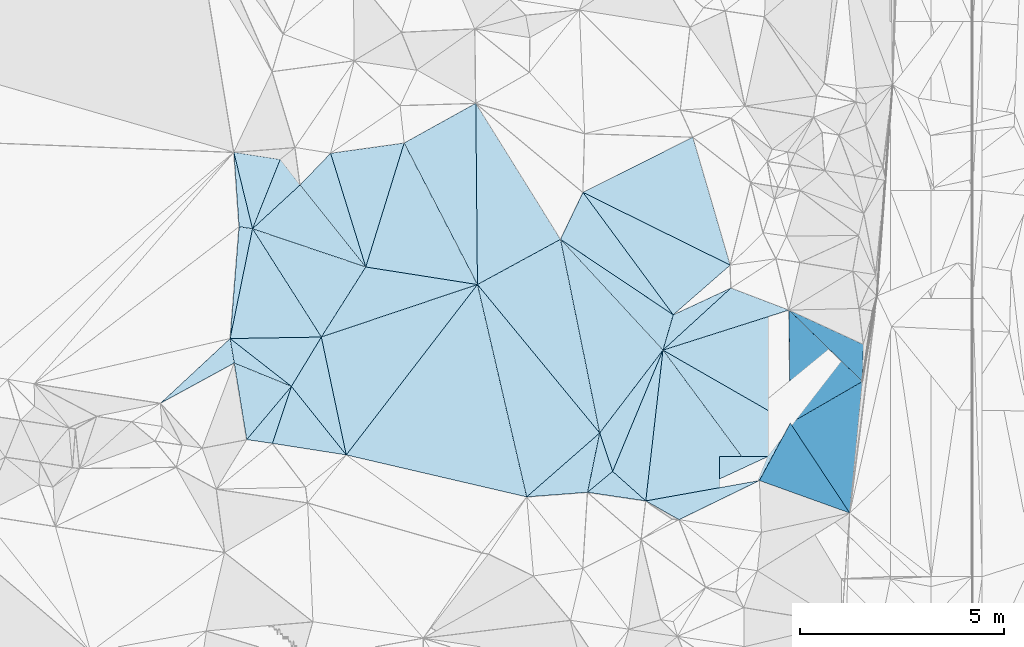
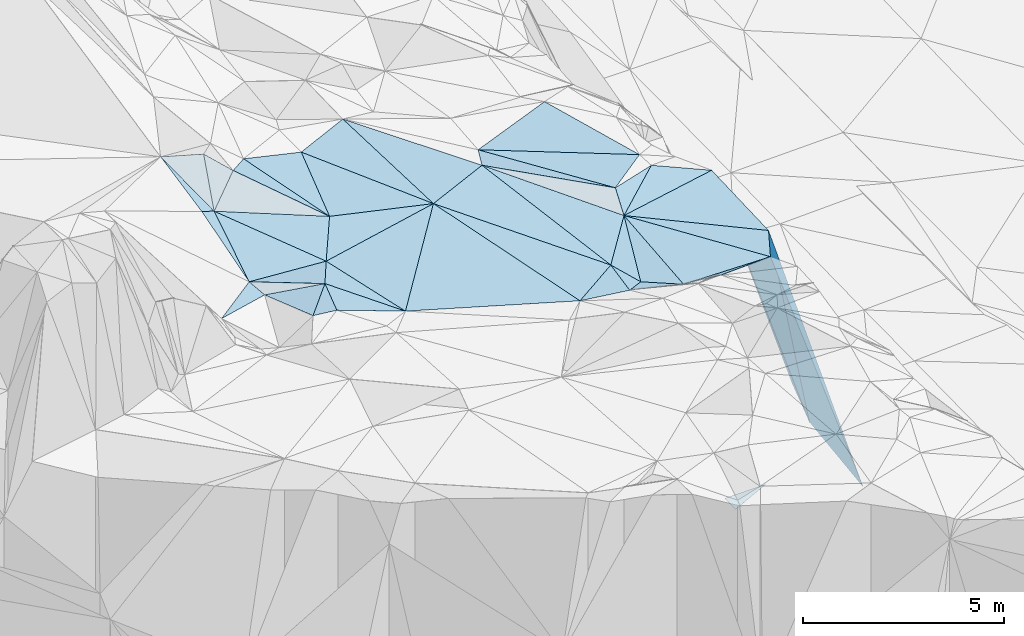
# One storey, part 127 of 275: 45 plates.
"""IFC2X3 building model written with IfcOpenShell, lengths in millimetres."""

from ifc_helpers import new_model, si_unit, frame, origin_with_axes, place, context, subcontext, project, spatial, polyline, outline, extrude, material, type_object, element, save


model = new_model("IFC2X3")

# Units and contexts
model_context = context("Model", 3, precision=1e-05, world=origin_with_axes())
body_context = subcontext(model_context, "Body", "Model", "MODEL_VIEW")
ifc_project = project(units=[si_unit("LENGTHUNIT", "METRE", prefix="MILLI"), si_unit("AREAUNIT", "SQUARE_METRE"), si_unit("VOLUMEUNIT", "CUBIC_METRE"), si_unit("MASSUNIT", "GRAM", prefix="KILO"), si_unit("TIMEUNIT", "SECOND"), si_unit("PLANEANGLEUNIT", "RADIAN"), si_unit("SOLIDANGLEUNIT", "STERADIAN"), si_unit("THERMODYNAMICTEMPERATUREUNIT", "DEGREE_CELSIUS"), si_unit("LUMINOUSINTENSITYUNIT", "LUMEN")], contexts=[model_context])

# Site, building, storey
site_placement = place(None, origin_with_axes())
site = spatial("IfcSite", under=ifc_project, at=site_placement, CompositionType="ELEMENT")
building_placement = place(site_placement, origin_with_axes())
building = spatial("IfcBuilding", under=site, at=building_placement, Name="Undefined", CompositionType="ELEMENT")
storey_placement = place(building_placement, origin_with_axes())
storey = spatial("IfcBuildingStorey", under=building, at=storey_placement, Name="Undefined", CompositionType="ELEMENT", Elevation=0.0)

# Plates
ifc_material = material()
plate_type_1 = type_object("IfcPlateType", PredefinedType="NOTDEFINED")
plate_1_placement = place(storey_placement, frame((-113290.924516379, 114127.260500849, 53479.508927416), z_axis=(-0.172709102162707, 0.0752053051916001, -0.982097616380974), x_axis=(0.930589104773864, -0.314271187618271, -0.187716644731307)))
element("IfcPlate", 1, at=plate_1_placement, inside=storey, type_object=plate_type_1, material=ifc_material, Name="00", context=body_context, shape_type="SweptSolid", body=[
    extrude(outline(polyline([(0.0, 0.0), (2983.2197265625, 1.45373633131385e-08), (2498.30737304688, 1975.21142578125), (0.0, 0.0)])), frame((-8.85201319254618e-08, 2.18876761149539e-07, -0.5000001331573), z_axis=(0.0, 0.0, 1.0), x_axis=(1.0, 0.0, 0.0)), (0.0, 0.0, 1.0), 1.0),
])
plate_type_2 = type_object("IfcPlateType", PredefinedType="NOTDEFINED")
plate_2_placement = place(storey_placement, frame((-100142.417613451, 112133.663950851, 51329.8786760674), z_axis=(-0.970123067649742, 0.00204934980498017, -0.242604686226857), x_axis=(0.235700499270644, -0.229042311999375, -0.944449519009645)))
element("IfcPlate", 2, at=plate_2_placement, inside=storey, type_object=plate_type_2, material=ifc_material, Name="00", context=body_context, shape_type="SweptSolid", body=[
    extrude(outline(polyline([(0.0, 0.0), (7644.6650390625, 1.2892996892333e-08), (794.29248046875, 2661.82250976563), (0.0, 0.0)])), frame((-8.85201319254618e-08, 2.18876761149539e-07, -0.5000001331573), z_axis=(0.0, 0.0, 1.0), x_axis=(1.0, 0.0, 0.0)), (0.0, 0.0, 1.0), 1.0),
])
plate_type_3 = type_object("IfcPlateType", PredefinedType="NOTDEFINED")
plate_3_placement = place(storey_placement, frame((-102977.166585272, 112017.290992687, 51859.5340615484), z_axis=(-0.307575091997798, -0.192578028302466, -0.931832209036413), x_axis=(-0.820654845992236, 0.549332950676006, 0.157349715764129)))
element("IfcPlate", 3, at=plate_3_placement, inside=storey, type_object=plate_type_3, material=ifc_material, Name="00", context=body_context, shape_type="SweptSolid", body=[
    extrude(outline(polyline([(0.0, 0.0), (3368.29345703125, -2.82307155430317e-08), (3482.03051757813, 1339.12805175781), (0.0, 0.0)])), frame((-8.85201319254618e-08, 2.18876761149539e-07, -0.5000001331573), z_axis=(0.0, 0.0, 1.0), x_axis=(1.0, 0.0, 0.0)), (0.0, 0.0, 1.0), 1.0),
])
plate_type_4 = type_object("IfcPlateType", PredefinedType="NOTDEFINED")
plate_4_placement = place(storey_placement, frame((-103228.629908581, 111151.950283481, 51629.548500811), z_axis=(-0.284072273763953, 0.322455013222665, -0.902953879069218), x_axis=(0.270325176584008, 0.930481862748815, 0.247240372917369)))
element("IfcPlate", 4, at=plate_4_placement, inside=storey, type_object=plate_type_4, material=ifc_material, Name="00", context=body_context, shape_type="SweptSolid", body=[
    extrude(outline(polyline([(0.0, 0.0), (930.268798828125, -2.6775524020195e-09), (1873.22204589844, 1260.72961425781), (0.0, 0.0)])), frame((-8.85201319254618e-08, 2.18876761149539e-07, -0.5000001331573), z_axis=(0.0, 0.0, 1.0), x_axis=(1.0, 0.0, 0.0)), (0.0, 0.0, 1.0), 1.0),
])
plate_type_5 = type_object("IfcPlateType", PredefinedType="NOTDEFINED")
plate_5_placement = place(storey_placement, frame((-101843.498270915, 107992.439060405, 44125.3050804354), z_axis=(0.0127811447682837, 0.0127271104742126, -0.999837318266021), x_axis=(0.00421432091108771, 0.999909427151692, 0.0127819009710444)))
element("IfcPlate", 5, at=plate_5_placement, inside=storey, type_object=plate_type_5, material=ifc_material, Name="00_PR", context=body_context, shape_type="SweptSolid", body=[
    extrude(outline(polyline([(0.0, 0.0), (550.387634277344, -1.93540472537279e-09), (555.515625, 1186.86450195313), (0.0, 0.0)])), frame((-8.85201319254618e-08, 2.18876761149539e-07, -0.5000001331573), z_axis=(0.0, 0.0, 1.0), x_axis=(1.0, 0.0, 0.0)), (0.0, 0.0, 1.0), 1.0),
])
plate_type_6 = type_object("IfcPlateType", PredefinedType="NOTDEFINED")
plate_6_placement = place(storey_placement, frame((-110992.967145361, 108582.937779977, 52999.5228277071), z_axis=(-0.29101831444903, -0.0680980094244274, -0.954290837097201), x_axis=(-0.619116988685024, 0.773853922782803, 0.133582410950151)))
element("IfcPlate", 6, at=plate_6_placement, inside=storey, type_object=plate_type_6, material=ifc_material, Name="00", context=body_context, shape_type="SweptSolid", body=[
    extrude(outline(polyline([(0.0, 0.0), (2170.94458007813, -1.24782673083246e-08), (2611.72045898438, 1379.67993164063), (0.0, 0.0)])), frame((-8.85201319254618e-08, 2.18876761149539e-07, -0.5000001331573), z_axis=(0.0, 0.0, 1.0), x_axis=(1.0, 0.0, 0.0)), (0.0, 0.0, 1.0), 1.0),
])
plate_type_7 = type_object("IfcPlateType", PredefinedType="NOTDEFINED")
plate_7_placement = place(storey_placement, frame((-100107.835277105, 109360.708064252, 51169.5040323269), z_axis=(-0.114166513399481, 0.0558255965218635, -0.991891884224881), x_axis=(-0.860300500120834, 0.493763292727245, 0.126810331783303)))
element("IfcPlate", 7, at=plate_7_placement, inside=storey, type_object=plate_type_7, material=ifc_material, Name="00", context=body_context, shape_type="SweptSolid", body=[
    extrude(outline(polyline([(0.0, 0.0), (3627.46459960938, -1.69238774105906e-08), (1418.86975097656, 2388.09716796875), (0.0, 0.0)])), frame((-8.85201319254618e-08, 2.18876761149539e-07, -0.5000001331573), z_axis=(0.0, 0.0, 1.0), x_axis=(1.0, 0.0, 0.0)), (0.0, 0.0, 1.0), 1.0),
])
plate_type_8 = type_object("IfcPlateType", PredefinedType="NOTDEFINED")
plate_8_placement = place(storey_placement, frame((-110514.737169494, 113189.818368052, 52919.5213666835), z_axis=(-0.101585927605892, 0.270947890734014, -0.957218647864342), x_axis=(-0.93058910476547, 0.314271187650288, 0.187716644719318)))
element("IfcPlate", 8, at=plate_8_placement, inside=storey, type_object=plate_type_8, material=ifc_material, Name="00", context=body_context, shape_type="SweptSolid", body=[
    extrude(outline(polyline([(0.0, 0.0), (2983.2197265625, 1.45373633131385e-08), (2269.42724609375, 1425.83312988281), (0.0, 0.0)])), frame((-8.85201319254618e-08, 2.18876761149539e-07, -0.5000001331573), z_axis=(0.0, 0.0, 1.0), x_axis=(1.0, 0.0, 0.0)), (0.0, 0.0, 1.0), 1.0),
])
plate_type_9 = type_object("IfcPlateType", PredefinedType="NOTDEFINED")
plate_9_placement = place(storey_placement, frame((-113839.438935646, 111435.675310695, 53159.5175221802), z_axis=(-0.210092793816043, 0.157527560683942, -0.964907293791241), x_axis=(0.0789804476908692, 0.986443208708508, 0.143846740927325)))
element("IfcPlate", 9, at=plate_9_placement, inside=storey, type_object=plate_type_9, material=ifc_material, Name="00", context=body_context, shape_type="SweptSolid", body=[
    extrude(outline(polyline([(0.0, 0.0), (2780.7373046875, -1.69093254953623e-08), (2744.48803710938, 340.420288085938), (0.0, 0.0)])), frame((-8.85201319254618e-08, 2.18876761149539e-07, -0.5000001331573), z_axis=(0.0, 0.0, 1.0), x_axis=(1.0, 0.0, 0.0)), (0.0, 0.0, 1.0), 1.0),
])
plate_type_10 = type_object("IfcPlateType", PredefinedType="NOTDEFINED")
plate_10_placement = place(storey_placement, frame((-112610.336796461, 115827.769253173, 53949.5317938835), z_axis=(-0.148263509846929, 0.318162179256301, -0.936371058576006), x_axis=(0.574478656523812, -0.742992933734673, -0.343417782910175)))
element("IfcPlate", 10, at=plate_10_placement, inside=storey, type_object=plate_type_10, material=ifc_material, Name="00", context=body_context, shape_type="SweptSolid", body=[
    extrude(outline(polyline([(0.0, 0.0), (844.452514648438, 7.05767888575792e-10), (1033.80590820313, 1583.23889160156), (0.0, 0.0)])), frame((-8.85201319254618e-08, 2.18876761149539e-07, -0.5000001331573), z_axis=(0.0, 0.0, 1.0), x_axis=(1.0, 0.0, 0.0)), (0.0, 0.0, 1.0), 1.0),
])
plate_type_11 = type_object("IfcPlateType", PredefinedType="NOTDEFINED")
plate_11_placement = place(storey_placement, frame((-113737.933071278, 110835.227286882, 53089.5108445569), z_axis=(0.0583514382683411, -0.198996312223613, -0.978261507662148), x_axis=(0.917754651260119, -0.374917907802847, 0.131007490240644)))
element("IfcPlate", 11, at=plate_11_placement, inside=storey, type_object=plate_type_11, material=ifc_material, Name="00", context=body_context, shape_type="SweptSolid", body=[
    extrude(outline(polyline([(0.0, 0.0), (1526.63024902344, -7.6397554948926e-09), (1036.00720214844, 1643.98571777344), (0.0, 0.0)])), frame((-8.85201319254618e-08, 2.18876761149539e-07, -0.5000001331573), z_axis=(0.0, 0.0, 1.0), x_axis=(1.0, 0.0, 0.0)), (0.0, 0.0, 1.0), 1.0),
])
plate_type_12 = type_object("IfcPlateType", PredefinedType="NOTDEFINED")
plate_12_placement = place(storey_placement, frame((-103228.56014108, 111151.757225135, 51629.5062530641), z_axis=(-0.144539528359727, -0.0636647869544907, -0.987448793428594), x_axis=(0.594289133399579, -0.803481388047047, -0.0351864318334244)))
element("IfcPlate", 12, at=plate_12_placement, inside=storey, type_object=plate_type_12, material=ifc_material, Name="00", context=body_context, shape_type="SweptSolid", body=[
    extrude(outline(polyline([(0.0, 0.0), (3978.80639648438, -1.68292899616063e-08), (2708.65161132813, 2567.43188476563), (0.0, 0.0)])), frame((-8.85201319254618e-08, 2.18876761149539e-07, -0.5000001331573), z_axis=(0.0, 0.0, 1.0), x_axis=(1.0, 0.0, 0.0)), (0.0, 0.0, 1.0), 1.0),
])
plate_type_13 = type_object("IfcPlateType", PredefinedType="NOTDEFINED")
plate_13_placement = place(storey_placement, frame((-104461.963035231, 108179.238645933, 51849.5069629809), z_axis=(-0.166530624901498, -0.00387841645301839, -0.986028655189966), x_axis=(-0.319474542315838, 0.946262410014072, 0.0502341338777444)))
element("IfcPlate", 13, at=plate_13_placement, inside=storey, type_object=plate_type_13, material=ifc_material, Name="00", context=body_context, shape_type="SweptSolid", body=[
    extrude(outline(polyline([(0.0, 0.0), (995.339111328125, 3.81260178983212e-09), (2407.72216796875, 2146.75903320313), (0.0, 0.0)])), frame((-8.85201319254618e-08, 2.18876761149539e-07, -0.5000001331573), z_axis=(0.0, 0.0, 1.0), x_axis=(1.0, 0.0, 0.0)), (0.0, 0.0, 1.0), 1.0),
])
plate_type_14 = type_object("IfcPlateType", PredefinedType="NOTDEFINED")
plate_14_placement = place(storey_placement, frame((-107777.185867756, 112759.879968999, 52609.5026031862), z_axis=(-0.0991276842168737, -0.025519348889009, -0.994747437822325), x_axis=(-0.459635479101893, 0.887809085579486, 0.0230272428504011)))
element("IfcPlate", 14, at=plate_14_placement, inside=storey, type_object=plate_type_14, material=ifc_material, Name="00", context=body_context, shape_type="SweptSolid", body=[
    extrude(outline(polyline([(0.0, 0.0), (3908.4140625, 7.01402314007282e-09), (3960.60913085938, 2017.34375), (0.0, 0.0)])), frame((-8.85201319254618e-08, 2.18876761149539e-07, -0.5000001331573), z_axis=(0.0, 0.0, 1.0), x_axis=(1.0, 0.0, 0.0)), (0.0, 0.0, 1.0), 1.0),
])
plate_type_15 = type_object("IfcPlateType", PredefinedType="NOTDEFINED")
plate_15_placement = place(storey_placement, frame((-104780.041248079, 109121.057966217, 51899.5332455882), z_axis=(-0.351922481048274, -0.0692604473999243, -0.933463206430114), x_axis=(0.319474542309038, -0.946262410016143, -0.0502341338819766)))
element("IfcPlate", 15, at=plate_15_placement, inside=storey, type_object=plate_type_15, material=ifc_material, Name="00", context=body_context, shape_type="SweptSolid", body=[
    extrude(outline(polyline([(0.0, 0.0), (995.339111328125, 3.81260178983212e-09), (1270.22033691406, 799.149780273438), (0.0, 0.0)])), frame((-8.85201319254618e-08, 2.18876761149539e-07, -0.5000001331573), z_axis=(0.0, 0.0, 1.0), x_axis=(1.0, 0.0, 0.0)), (0.0, 0.0, 1.0), 1.0),
])
plate_type_16 = type_object("IfcPlateType", PredefinedType="NOTDEFINED")
plate_16_placement = place(storey_placement, frame((-110992.955705904, 108582.947589555, 52999.518908875), z_axis=(-0.268224136041974, -0.0485076973734899, -0.962134510419442), x_axis=(-0.954406350383187, 0.149203927812426, 0.25854729987681)))
element("IfcPlate", 16, at=plate_16_placement, inside=storey, type_object=plate_type_16, material=ifc_material, Name="00", context=body_context, shape_type="SweptSolid", body=[
    extrude(outline(polyline([(0.0, 0.0), (1895.20446777344, -1.19907781481743e-08), (1608.42797851563, 1458.06701660156), (0.0, 0.0)])), frame((-8.85201319254618e-08, 2.18876761149539e-07, -0.5000001331573), z_axis=(0.0, 0.0, 1.0), x_axis=(1.0, 0.0, 0.0)), (0.0, 0.0, 1.0), 1.0),
])
plate_type_17 = type_object("IfcPlateType", PredefinedType="NOTDEFINED")
plate_17_placement = place(storey_placement, frame((-102834.585362584, 106995.936334038, 52199.58261088), z_axis=(-0.0333523932405927, -0.549645033444782, -0.8347322655047), x_axis=(-0.837062108986738, 0.471708938718969, -0.277160067165706)))
element("IfcPlate", 17, at=plate_17_placement, inside=storey, type_object=plate_type_17, material=ifc_material, Name="00", context=body_context, shape_type="SweptSolid", body=[
    extrude(outline(polyline([(0.0, 0.0), (974.166320800781, -4.18367562815547e-10), (-1000.5478515625, 2074.97094726563), (0.0, 0.0)])), frame((-8.85201319254618e-08, 2.18876761149539e-07, -0.5000001331573), z_axis=(0.0, 0.0, 1.0), x_axis=(1.0, 0.0, 0.0)), (0.0, 0.0, 1.0), 1.0),
])
plate_type_18 = type_object("IfcPlateType", PredefinedType="NOTDEFINED")
plate_18_placement = place(storey_placement, frame((-110514.904767365, 113189.673467237, 52919.5502918693), z_axis=(-0.436782924119263, -0.0188441911042979, -0.89936954232365), x_axis=(-0.600878876265441, 0.75014145583279, 0.276102104843558)))
element("IfcPlate", 18, at=plate_18_placement, inside=storey, type_object=plate_type_18, material=ifc_material, Name="00", context=body_context, shape_type="SweptSolid", body=[
    extrude(outline(polyline([(0.0, 0.0), (2680.16796875, -1.56251189764589e-08), (2709.90478515625, 1145.25793457031), (0.0, 0.0)])), frame((-8.85201319254618e-08, 2.18876761149539e-07, -0.5000001331573), z_axis=(0.0, 0.0, 1.0), x_axis=(1.0, 0.0, 0.0)), (0.0, 0.0, 1.0), 1.0),
])
plate_type_19 = type_object("IfcPlateType", PredefinedType="NOTDEFINED")
plate_19_placement = place(storey_placement, frame((-113839.484608235, 111435.62658145, 53159.5241774874), z_axis=(-0.301427978837566, 0.0600653433552318, -0.95159514926334), x_axis=(0.165428958309485, -0.979583580993424, -0.114233390918502)))
element("IfcPlate", 19, at=plate_19_placement, inside=storey, type_object=plate_type_19, material=ifc_material, Name="00", context=body_context, shape_type="SweptSolid", body=[
    extrude(outline(polyline([(0.0, 0.0), (612.780517578125, -7.8580342233181e-10), (1220.01257324219, 2030.46032714844), (0.0, 0.0)])), frame((-8.85201319254618e-08, 2.18876761149539e-07, -0.5000001331573), z_axis=(0.0, 0.0, 1.0), x_axis=(1.0, 0.0, 0.0)), (0.0, 0.0, 1.0), 1.0),
])
plate_type_20 = type_object("IfcPlateType", PredefinedType="NOTDEFINED")
plate_20_placement = place(storey_placement, frame((-104779.949596278, 109121.035778493, 51899.5104226752), z_axis=(-0.168618068721851, -0.113635619617306, -0.979109234383327), x_axis=(-0.198111840674355, -0.969154603678011, 0.146598269956834)))
element("IfcPlate", 20, at=plate_20_placement, inside=storey, type_object=plate_type_20, material=ifc_material, Name="00", context=body_context, shape_type="SweptSolid", body=[
    extrude(outline(polyline([(0.0, 0.0), (1500.69982910156, 6.69388100504875e-10), (1945.1591796875, 1453.77294921875), (0.0, 0.0)])), frame((-8.85201319254618e-08, 2.18876761149539e-07, -0.5000001331573), z_axis=(0.0, 0.0, 1.0), x_axis=(1.0, 0.0, 0.0)), (0.0, 0.0, 1.0), 1.0),
])
plate_type_21 = type_object("IfcPlateType", PredefinedType="NOTDEFINED")
plate_21_placement = place(storey_placement, frame((-105741.337585058, 113867.727864384, 52389.5149305392), z_axis=(-0.2370694404992, 0.0521294264640702, -0.970093090006275), x_axis=(0.665228069168794, -0.719018972740541, -0.201204703794659)))
element("IfcPlate", 21, at=plate_21_placement, inside=storey, type_object=plate_type_21, material=ifc_material, Name="00", context=body_context, shape_type="SweptSolid", body=[
    extrude(outline(polyline([(0.0, 0.0), (3777.24755859375, -8.95215634955093e-09), (4151.01171875, 2542.380859375), (0.0, 0.0)])), frame((-8.85201319254618e-08, 2.18876761149539e-07, -0.5000001331573), z_axis=(0.0, 0.0, 1.0), x_axis=(1.0, 0.0, 0.0)), (0.0, 0.0, 1.0), 1.0),
])
plate_type_22 = type_object("IfcPlateType", PredefinedType="NOTDEFINED")
plate_22_placement = place(storey_placement, frame((-112336.791116112, 110263.03900113, 53289.5153976112), z_axis=(0.198187130186862, 0.146486609096265, -0.96915609412714), x_axis=(-0.917754651256828, 0.374917907810703, -0.131007490241218)))
element("IfcPlate", 22, at=plate_22_placement, inside=storey, type_object=plate_type_22, material=ifc_material, Name="00", context=body_context, shape_type="SweptSolid", body=[
    extrude(outline(polyline([(0.0, 0.0), (1526.63024902344, -7.6397554948926e-09), (1835.5458984375, 529.217468261719), (0.0, 0.0)])), frame((-8.85201319254618e-08, 2.18876761149539e-07, -0.5000001331573), z_axis=(0.0, 0.0, 1.0), x_axis=(1.0, 0.0, 0.0)), (0.0, 0.0, 1.0), 1.0),
])
plate_type_23 = type_object("IfcPlateType", PredefinedType="NOTDEFINED")
plate_23_placement = place(storey_placement, frame((-113748.215588472, 116002.601177061, 54159.5310789013), z_axis=(-0.181896441513606, 0.295710479889402, -0.937800083519013), x_axis=(0.223452360599115, -0.916328731968676, -0.332281051989671)))
element("IfcPlate", 23, at=plate_23_placement, inside=storey, type_object=plate_type_23, material=ifc_material, Name="00", context=body_context, shape_type="SweptSolid", body=[
    extrude(outline(polyline([(0.0, 0.0), (2046.46032714844, -2.00816430151463e-09), (1899.27941894531, 309.091827392578), (0.0, 0.0)])), frame((-8.85201319254618e-08, 2.18876761149539e-07, -0.5000001331573), z_axis=(0.0, 0.0, 1.0), x_axis=(1.0, 0.0, 0.0)), (0.0, 0.0, 1.0), 1.0),
])
plate_type_24 = type_object("IfcPlateType", PredefinedType="NOTDEFINED")
plate_24_placement = place(storey_placement, frame((-105741.224655532, 113867.831714132, 52389.5171822448), z_axis=(-0.0112150066889495, 0.25982723406388, -0.965589991696103), x_axis=(0.820654845998658, -0.549332950666157, -0.157349715765021)))
element("IfcPlate", 24, at=plate_24_placement, inside=storey, type_object=plate_type_24, material=ifc_material, Name="00", context=body_context, shape_type="SweptSolid", body=[
    extrude(outline(polyline([(0.0, 0.0), (3368.29345703125, -2.82307155430317e-08), (3673.61108398438, 878.738342285156), (0.0, 0.0)])), frame((-8.85201319254618e-08, 2.18876761149539e-07, -0.5000001331573), z_axis=(0.0, 0.0, 1.0), x_axis=(1.0, 0.0, 0.0)), (0.0, 0.0, 1.0), 1.0),
])
plate_type_25 = type_object("IfcPlateType", PredefinedType="NOTDEFINED")
plate_25_placement = place(storey_placement, frame((-112801.626696517, 108865.676193202, 53489.5046659798), z_axis=(-0.0198339968463662, -0.135201519252385, -0.990619584785676), x_axis=(-0.989410247668502, 0.145146001696751, -2.12786690931765e-10)))
element("IfcPlate", 25, at=plate_25_placement, inside=storey, type_object=plate_type_25, material=ifc_material, Name="00", context=body_context, shape_type="SweptSolid", body=[
    extrude(outline(polyline([(0.0, 0.0), (638.122253417969, -7.8580342233181e-10), (-257.004058837891, 1463.60815429688), (0.0, 0.0)])), frame((-8.85201319254618e-08, 2.18876761149539e-07, -0.5000001331573), z_axis=(0.0, 0.0, 1.0), x_axis=(1.0, 0.0, 0.0)), (0.0, 0.0, 1.0), 1.0),
])
plate_type_26 = type_object("IfcPlateType", PredefinedType="NOTDEFINED")
plate_26_placement = place(storey_placement, frame((-101580.597504038, 113236.099407996, 51639.502625087), z_axis=(-0.100805033743172, -0.0199465061998059, -0.994706229025665), x_axis=(-0.893568103053373, 0.441430120702552, 0.0817036947887111)))
element("IfcPlate", 26, at=plate_26_placement, inside=storey, type_object=plate_type_26, material=ifc_material, Name="00", context=body_context, shape_type="SweptSolid", body=[
    extrude(outline(polyline([(0.0, 0.0), (4038.98510742188, 1.01790647022426e-08), (2206.51977539063, 2411.36279296875), (0.0, 0.0)])), frame((-8.85201319254618e-08, 2.18876761149539e-07, -0.5000001331573), z_axis=(0.0, 0.0, 1.0), x_axis=(1.0, 0.0, 0.0)), (0.0, 0.0, 1.0), 1.0),
])
plate_type_27 = type_object("IfcPlateType", PredefinedType="NOTDEFINED")
plate_27_placement = place(storey_placement, frame((-111376.471149329, 115979.533994549, 53279.5247295516), z_axis=(-0.309561047461995, 0.0270449698826174, -0.950494885571869), x_axis=(0.943736490806287, 0.131031556221101, -0.303631630754954)))
element("IfcPlate", 27, at=plate_27_placement, inside=storey, type_object=plate_type_27, material=ifc_material, Name="00", context=body_context, shape_type="SweptSolid", body=[
    extrude(outline(polyline([(0.0, 0.0), (1910.20947265625, -4.86033968627453e-09), (556.902282714844, 2888.78173828125), (0.0, 0.0)])), frame((-8.85201319254618e-08, 2.18876761149539e-07, -0.5000001331573), z_axis=(0.0, 0.0, 1.0), x_axis=(1.0, 0.0, 0.0)), (0.0, 0.0, 1.0), 1.0),
])
plate_type_28 = type_object("IfcPlateType", PredefinedType="NOTDEFINED")
plate_28_placement = place(storey_placement, frame((-101562.431503885, 112675.690510193, 51649.5138021892), z_axis=(-0.151137466860157, 0.178015342504103, -0.972351790220104), x_axis=(0.91427357332773, -0.348825657830613, -0.205972069838569)))
element("IfcPlate", 28, at=plate_28_placement, inside=storey, type_object=plate_type_28, material=ifc_material, Name="00", context=body_context, shape_type="SweptSolid", body=[
    extrude(outline(polyline([(0.0, 0.0), (1553.60864257813, -1.22236087918282e-09), (-987.636047363281, 2030.51098632813), (0.0, 0.0)])), frame((-8.85201319254618e-08, 2.18876761149539e-07, -0.5000001331573), z_axis=(0.0, 0.0, 1.0), x_axis=(1.0, 0.0, 0.0)), (0.0, 0.0, 1.0), 1.0),
])
plate_type_29 = type_object("IfcPlateType", PredefinedType="NOTDEFINED")
plate_29_placement = place(storey_placement, frame((-106569.006657726, 107553.866921088, 52389.5045239493), z_axis=(-0.134134289740589, 0.0107449362066474, -0.990904908990617), x_axis=(-0.965326529404301, 0.224560118841197, 0.133106891836125)))
element("IfcPlate", 29, at=plate_29_placement, inside=storey, type_object=plate_type_29, material=ifc_material, Name="00", context=body_context, shape_type="SweptSolid", body=[
    extrude(outline(polyline([(0.0, 0.0), (4582.783203125, 5.45696821063757e-09), (2364.65478515625, 4797.84423828125), (0.0, 0.0)])), frame((-8.85201319254618e-08, 2.18876761149539e-07, -0.5000001331573), z_axis=(0.0, 0.0, 1.0), x_axis=(1.0, 0.0, 0.0)), (0.0, 0.0, 1.0), 1.0),
])
plate_type_30 = type_object("IfcPlateType", PredefinedType="NOTDEFINED")
plate_30_placement = place(storey_placement, frame((-103650.090708637, 107455.587473051, 51929.5294588312), z_axis=(-0.168630707463904, -0.293279681088311, -0.941037041333104), x_axis=(-0.980782762690523, 0.144968828691952, 0.130572627747274)))
element("IfcPlate", 30, at=plate_30_placement, inside=storey, type_object=plate_type_30, material=ifc_material, Name="00", context=body_context, shape_type="SweptSolid", body=[
    extrude(outline(polyline([(0.0, 0.0), (1455.12890625, -3.87080945074558e-09), (890.711486816406, 628.99365234375), (0.0, 0.0)])), frame((-8.85201319254618e-08, 2.18876761149539e-07, -0.5000001331573), z_axis=(0.0, 0.0, 1.0), x_axis=(1.0, 0.0, 0.0)), (0.0, 0.0, 1.0), 1.0),
])
plate_type_31 = type_object("IfcPlateType", PredefinedType="NOTDEFINED")
plate_31_placement = place(storey_placement, frame((-103649.994541616, 107455.692332826, 51929.5018672791), z_axis=(0.0236970316771958, -0.0835634052652213, -0.996220662298354), x_axis=(-0.744556012994873, 0.663516140656342, -0.0733667131722052)))
element("IfcPlate", 31, at=plate_31_placement, inside=storey, type_object=plate_type_31, material=ifc_material, Name="00", context=body_context, shape_type="SweptSolid", body=[
    extrude(outline(polyline([(0.0, 0.0), (1090.41271972656, -4.68207872472703e-09), (2160.55786132813, 3043.10522460938), (0.0, 0.0)])), frame((-8.85201319254618e-08, 2.18876761149539e-07, -0.5000001331573), z_axis=(0.0, 0.0, 1.0), x_axis=(1.0, 0.0, 0.0)), (0.0, 0.0, 1.0), 1.0),
])
plate_type_32 = type_object("IfcPlateType", PredefinedType="NOTDEFINED")
plate_32_placement = place(storey_placement, frame((-107777.261366539, 112759.884164985, 52609.5159452071), z_axis=(-0.250123778632315, -0.01713878544426, -0.968062166080355), x_axis=(0.62869451505426, -0.76325886959914, -0.148926507777939)))
element("IfcPlate", 32, at=plate_32_placement, inside=storey, type_object=plate_type_32, material=ifc_material, Name="00", context=body_context, shape_type="SweptSolid", body=[
    extrude(outline(polyline([(0.0, 0.0), (4767.4521484375, 1.72440195456147e-08), (4765.89990234375, 2428.39404296875), (0.0, 0.0)])), frame((-8.85201319254618e-08, 2.18876761149539e-07, -0.5000001331573), z_axis=(0.0, 0.0, 1.0), x_axis=(1.0, 0.0, 0.0)), (0.0, 0.0, 1.0), 1.0),
])
plate_type_33 = type_object("IfcPlateType", PredefinedType="NOTDEFINED")
plate_33_placement = place(storey_placement, frame((-113839.371475843, 111435.494297788, 53159.5119873861), z_axis=(-0.0751653401216483, -0.204504688578669, -0.975975411572309), x_axis=(0.996637755432914, 0.0165995232864846, -0.0802349068193162)))
element("IfcPlate", 33, at=plate_33_placement, inside=storey, type_object=plate_type_33, material=ifc_material, Name="00", context=body_context, shape_type="SweptSolid", body=[
    extrude(outline(polyline([(0.0, 0.0), (2243.41259765625, -8.09086486697197e-09), (1467.49645996094, 1223.01025390625), (0.0, 0.0)])), frame((-8.85201319254618e-08, 2.18876761149539e-07, -0.5000001331573), z_axis=(0.0, 0.0, 1.0), x_axis=(1.0, 0.0, 0.0)), (0.0, 0.0, 1.0), 1.0),
])
plate_type_34 = type_object("IfcPlateType", PredefinedType="NOTDEFINED")
plate_34_placement = place(storey_placement, frame((-100108.21111449, 109360.878236301, 51169.8472003779), z_axis=(-0.865844299972751, 0.396168529602647, -0.305555468544048), x_axis=(0.195133392396839, -0.294958278163697, -0.935372959473604)))
element("IfcPlate", 34, at=plate_34_placement, inside=storey, type_object=plate_type_34, material=ifc_material, Name="00", context=body_context, shape_type="SweptSolid", body=[
    extrude(outline(polyline([(0.0, 0.0), (7465.47119140625, 1.23254721984267e-08), (-32.2203369140625, 1627.68603515625), (0.0, 0.0)])), frame((-8.85201319254618e-08, 2.18876761149539e-07, -0.5000001331573), z_axis=(0.0, 0.0, 1.0), x_axis=(1.0, 0.0, 0.0)), (0.0, 0.0, 1.0), 1.0),
])
plate_type_35 = type_object("IfcPlateType", PredefinedType="NOTDEFINED")
plate_35_placement = place(storey_placement, frame((-113290.879033995, 114127.289938952, 53479.506177514), z_axis=(-0.0817399136760823, 0.134069283100202, -0.987595065723409), x_axis=(0.529819730348138, -0.833452765992299, -0.156995350866236)))
element("IfcPlate", 35, at=plate_35_placement, inside=storey, type_object=plate_type_35, material=ifc_material, Name="00", context=body_context, shape_type="SweptSolid", body=[
    extrude(outline(polyline([(0.0, 0.0), (3184.8076171875, 8.37462721392512e-09), (2002.97802734375, 1906.87670898438), (0.0, 0.0)])), frame((-8.85201319254618e-08, 2.18876761149539e-07, -0.5000001331573), z_axis=(0.0, 0.0, 1.0), x_axis=(1.0, 0.0, 0.0)), (0.0, 0.0, 1.0), 1.0),
])
plate_type_36 = type_object("IfcPlateType", PredefinedType="NOTDEFINED")
plate_36_placement = place(storey_placement, frame((-110992.865462612, 108582.959127661, 52999.5020665887), z_axis=(-0.0877397285569031, -0.0254316418741894, -0.99581874436282), x_axis=(-0.20673516422217, 0.978373509707473, -0.0067710690968854)))
element("IfcPlate", 36, at=plate_36_placement, inside=storey, type_object=plate_type_36, material=ifc_material, Name="00", context=body_context, shape_type="SweptSolid", body=[
    extrude(outline(polyline([(0.0, 0.0), (2953.74340820313, -1.39552867040038e-08), (3424.43432617188, 4026.49340820313), (0.0, 0.0)])), frame((-8.85201319254618e-08, 2.18876761149539e-07, -0.5000001331573), z_axis=(0.0, 0.0, 1.0), x_axis=(1.0, 0.0, 0.0)), (0.0, 0.0, 1.0), 1.0),
])
plate_37_placement = place(storey_placement, frame((-107777.195262128, 112759.87506967, 52609.5037802463), z_axis=(-0.117922449415542, -0.0353107733394214, -0.992394803095024), x_axis=(-0.981774783692327, 0.154136775664298, 0.111176114762562)))
element("IfcPlate", 37, at=plate_37_placement, inside=storey, type_object=plate_type_36, material=ifc_material, Name="00", context=body_context, shape_type="SweptSolid", body=[
    extrude(outline(polyline([(0.0, 0.0), (2788.36865234375, 8.80390871316195e-09), (2308.55419921875, 3153.77197265625), (0.0, 0.0)])), frame((-8.85201319254618e-08, 2.18876761149539e-07, -0.5000001331573), z_axis=(0.0, 0.0, 1.0), x_axis=(1.0, 0.0, 0.0)), (0.0, 0.0, 1.0), 1.0),
])
plate_type_37 = type_object("IfcPlateType", PredefinedType="NOTDEFINED")
plate_38_placement = place(storey_placement, frame((-98340.5658607909, 110382.755217091, 44109.8850094044), z_axis=(-0.969219964131672, 0.0879824448398562, -0.229938579904724), x_axis=(-0.0959700787428879, -0.995100455254249, 0.0237661090393667)))
element("IfcPlate", 38, at=plate_38_placement, inside=storey, type_object=plate_type_37, material=ifc_material, Name="00", context=body_context, shape_type="SweptSolid", body=[
    extrude(outline(polyline([(0.0, 0.0), (3239.90771484375, 1.01863406598568e-09), (1354.45837402344, 7223.4580078125), (0.0, 0.0)])), frame((-8.85201319254618e-08, 2.18876761149539e-07, -0.5000001331573), z_axis=(0.0, 0.0, 1.0), x_axis=(1.0, 0.0, 0.0)), (0.0, 0.0, 1.0), 1.0),
])
plate_type_38 = type_object("IfcPlateType", PredefinedType="NOTDEFINED")
plate_39_placement = place(storey_placement, frame((-103228.591148438, 111151.733955369, 51629.5138732735), z_axis=(-0.20655544090308, -0.110201789204841, -0.972209038987699), x_axis=(0.860300500105712, -0.493763292751797, -0.126810331790295)))
element("IfcPlate", 39, at=plate_39_placement, inside=storey, type_object=plate_type_38, material=ifc_material, Name="00", context=body_context, shape_type="SweptSolid", body=[
    extrude(outline(polyline([(0.0, 0.0), (3627.46459960938, -1.69238774105906e-08), (3630.4970703125, 1628.00207519531), (0.0, 0.0)])), frame((-8.85201319254618e-08, 2.18876761149539e-07, -0.5000001331573), z_axis=(0.0, 0.0, 1.0), x_axis=(1.0, 0.0, 0.0)), (0.0, 0.0, 1.0), 1.0),
])
plate_type_39 = type_object("IfcPlateType", PredefinedType="NOTDEFINED")
plate_40_placement = place(storey_placement, frame((-100142.399160337, 112133.771860231, 51329.8571121526), z_axis=(-0.933214751903617, 0.217868954194626, -0.285732997092761), x_axis=(0.264416829117068, -0.122046547923032, -0.95665478654515)))
element("IfcPlate", 40, at=plate_40_placement, inside=storey, type_object=plate_type_39, material=ifc_material, Name="00", context=body_context, shape_type="SweptSolid", body=[
    extrude(outline(polyline([(0.0, 0.0), (6909.49365234375, 7.23230186849833e-09), (7597.18505859375, 850.694091796875), (0.0, 0.0)])), frame((-8.85201319254618e-08, 2.18876761149539e-07, -0.5000001331573), z_axis=(0.0, 0.0, 1.0), x_axis=(1.0, 0.0, 0.0)), (0.0, 0.0, 1.0), 1.0),
])
plate_type_40 = type_object("IfcPlateType", PredefinedType="NOTDEFINED")
plate_41_placement = place(storey_placement, frame((-104779.938259792, 109121.128737597, 51899.5066542717), z_axis=(-0.145953146176467, 0.072292493899001, -0.986646580314884), x_axis=(-0.628694515051515, 0.763258869598996, 0.148926507790263)))
element("IfcPlate", 41, at=plate_41_placement, inside=storey, type_object=plate_type_40, material=ifc_material, Name="00", context=body_context, shape_type="SweptSolid", body=[
    extrude(outline(polyline([(0.0, 0.0), (4767.4521484375, 1.72440195456147e-08), (4300.26318359375, 2280.86279296875), (0.0, 0.0)])), frame((-8.85201319254618e-08, 2.18876761149539e-07, -0.5000001331573), z_axis=(0.0, 0.0, 1.0), x_axis=(1.0, 0.0, 0.0)), (0.0, 0.0, 1.0), 1.0),
])
plate_type_41 = type_object("IfcPlateType", PredefinedType="NOTDEFINED")
plate_42_placement = place(storey_placement, frame((-105189.71250296, 115019.015030675, 51969.5038421441), z_axis=(-0.114437852314946, -0.0479936781423239, -0.992270419198272), x_axis=(0.893568103050775, -0.441430120708441, -0.0817036947853056)))
element("IfcPlate", 42, at=plate_42_placement, inside=storey, type_object=plate_type_41, material=ifc_material, Name="00", context=body_context, shape_type="SweptSolid", body=[
    extrude(outline(polyline([(0.0, 0.0), (4038.98510742188, 1.01790647022426e-08), (3311.15356445313, 1718.73840332031), (0.0, 0.0)])), frame((-8.85201319254618e-08, 2.18876761149539e-07, -0.5000001331573), z_axis=(0.0, 0.0, 1.0), x_axis=(1.0, 0.0, 0.0)), (0.0, 0.0, 1.0), 1.0),
])
plate_type_42 = type_object("IfcPlateType", PredefinedType="NOTDEFINED")
plate_43_placement = place(storey_placement, frame((-107817.196410709, 117203.121923691, 52499.5023395861), z_axis=(-0.0936825719589964, -0.025483396814835, -0.99527592766927), x_axis=(0.528195818925575, -0.848661203333022, -0.027988190847013)))
element("IfcPlate", 43, at=plate_43_placement, inside=storey, type_object=plate_type_42, material=ifc_material, Name="00", context=body_context, shape_type="SweptSolid", body=[
    extrude(outline(polyline([(0.0, 0.0), (3930.22900390625, 2.20461515709758e-09), (3788.86328125, 2323.92236328125), (0.0, 0.0)])), frame((-8.85201319254618e-08, 2.18876761149539e-07, -0.5000001331573), z_axis=(0.0, 0.0, 1.0), x_axis=(1.0, 0.0, 0.0)), (0.0, 0.0, 1.0), 1.0),
])
plate_type_43 = type_object("IfcPlateType", PredefinedType="NOTDEFINED")
plate_44_placement = place(storey_placement, frame((-113290.901210868, 114127.378325623, 53479.5289494973), z_axis=(-0.126095720816472, 0.310860381739147, -0.942053975235372), x_axis=(-0.223452360365365, 0.916328732038671, 0.332281051953837)))
element("IfcPlate", 44, at=plate_44_placement, inside=storey, type_object=plate_type_43, material=ifc_material, Name="00", context=body_context, shape_type="SweptSolid", body=[
    extrude(outline(polyline([(0.0, 0.0), (2046.46032714844, -2.00816430151463e-09), (1562.20959472656, 1065.3173828125), (0.0, 0.0)])), frame((-8.85201319254618e-08, 2.18876761149539e-07, -0.5000001331573), z_axis=(0.0, 0.0, 1.0), x_axis=(1.0, 0.0, 0.0)), (0.0, 0.0, 1.0), 1.0),
])
plate_type_44 = type_object("IfcPlateType", PredefinedType="NOTDEFINED")
plate_45_placement = place(storey_placement, frame((-111603.517860677, 111472.852777512, 52979.5031421801), z_axis=(-0.107292562025443, 0.0333155040768865, -0.993669151841859), x_axis=(0.535324978063915, 0.844130847647903, -0.0295005069465189)))
element("IfcPlate", 45, at=plate_45_placement, inside=storey, type_object=plate_type_44, material=ifc_material, Name="00", context=body_context, shape_type="SweptSolid", body=[
    extrude(outline(polyline([(0.0, 0.0), (2033.86328125, 4.62750904262066e-09), (3145.68823242188, 2557.11669921875), (0.0, 0.0)])), frame((-8.85201319254618e-08, 2.18876761149539e-07, -0.5000001331573), z_axis=(0.0, 0.0, 1.0), x_axis=(1.0, 0.0, 0.0)), (0.0, 0.0, 1.0), 1.0),
])

save(model, "model.ifc")
